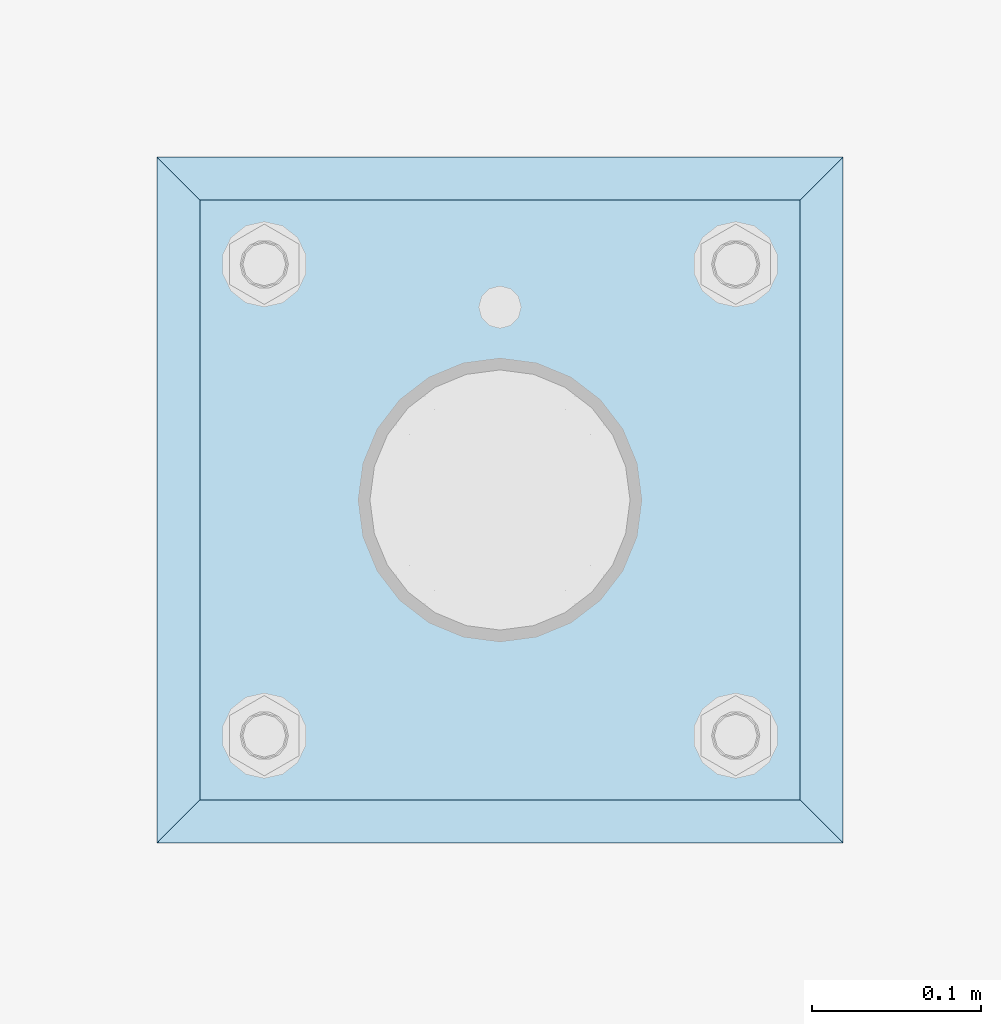
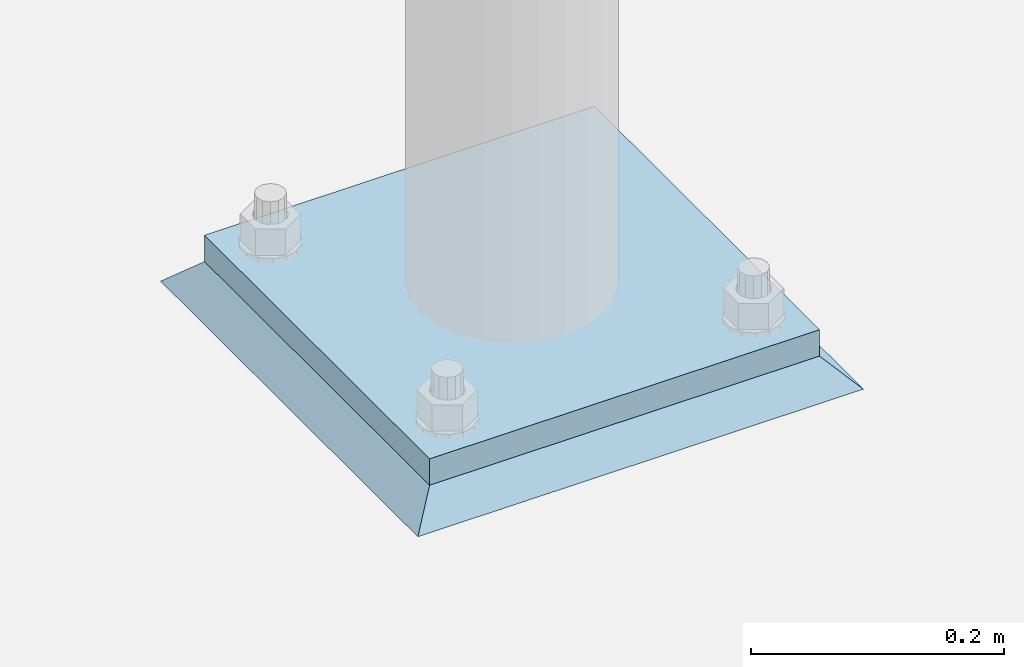
# One storey, part 3421 of 3843: 2 plates, 2 elements without a shape of their own.
"""IFC2X3 building model written with IfcOpenShell, lengths in millimetres."""

from ifc_helpers import new_model, si_unit, frame, origin_with_axes, place, context, subcontext, project, spatial, faceted_brep, material, type_object, element, aggregate, save


model = new_model("IFC2X3")

# Units and contexts
model_context = context("Model", 3, precision=1e-05, world=origin_with_axes())
body_context = subcontext(model_context, "Body", "Model", "MODEL_VIEW")
ifc_project = project(units=[si_unit("LENGTHUNIT", "METRE", prefix="MILLI"), si_unit("AREAUNIT", "SQUARE_METRE"), si_unit("VOLUMEUNIT", "CUBIC_METRE"), si_unit("MASSUNIT", "GRAM", prefix="KILO"), si_unit("TIMEUNIT", "SECOND"), si_unit("PLANEANGLEUNIT", "RADIAN"), si_unit("SOLIDANGLEUNIT", "STERADIAN"), si_unit("THERMODYNAMICTEMPERATUREUNIT", "DEGREE_CELSIUS"), si_unit("LUMINOUSINTENSITYUNIT", "LUMEN")], contexts=[model_context])

# Site, building, storey
site_placement = place(None, origin_with_axes())
site = spatial("IfcSite", under=ifc_project, at=site_placement, CompositionType="ELEMENT")
building_placement = place(site_placement, origin_with_axes())
building = spatial("IfcBuilding", under=site, at=building_placement, Name="Undefined", CompositionType="ELEMENT")
storey_placement = place(building_placement, origin_with_axes())
storey = spatial("IfcBuildingStorey", under=building, at=storey_placement, Name="Undefined", CompositionType="ELEMENT", Elevation=0.0)

# Assembly, plate
assembly_1_placement = place(storey_placement, origin_with_axes())
assembly_1 = element("IfcElementAssembly", 1, at=assembly_1_placement, inside=storey, Name="PIPE_BOLLARD", AssemblyPlace="NOTDEFINED", PredefinedType="RIGID_FRAME")
ifc_material_1 = material(Name="STEEL/A572-50")
plate_type_1 = type_object("IfcPlateType", PredefinedType="NOTDEFINED")
plate_1_placement = place(assembly_1_placement, frame((42672.0, 91427.3, 30518.1), z_axis=(0.0, 1.0, 0.0), x_axis=(1.0, 0.0, 0.0)))
plate_1 = element("IfcPlate", 2, at=plate_1_placement, type_object=plate_type_1, material=ifc_material_1, Name="PLATE", context=body_context, shape_type="Brep", body=[
    faceted_brep([(0.0, -12.6999999999971, 0.0), (0.0, -12.7000000000007, 355.600000000006), (0.0, 12.7000000000007, 355.600000000006), (0.0, 12.6999999999971, 0.0), (355.599999999999, -12.7000000000007, 355.600000000006), (355.599999999999, 12.7000000000007, 355.600000000006), (355.599999999999, -12.7000000000007, 0.0), (355.599999999999, 12.7000000000007, 0.0)], [[[0, 1, 2, 3]], [[1, 4, 5, 2]], [[4, 6, 7, 5]], [[6, 0, 3, 7]], [[5, 7, 3, 2]], [[6, 4, 1, 0]]]),
])
aggregate(assembly_1, [plate_1])

assembly_2_placement = place(storey_placement, origin_with_axes())
assembly_2 = element("IfcElementAssembly", 3, at=assembly_2_placement, inside=storey, Name="GROUT", AssemblyPlace="NOTDEFINED", PredefinedType="REINFORCEMENT_UNIT")
ifc_material_2 = material(Name="CONCRETE/Concrete_Undefined")
plate_type_2 = type_object("IfcPlateType", PredefinedType="NOTDEFINED")
plate_2_placement = place(assembly_2_placement, frame((42646.6, 91401.9, 30492.7), z_axis=(0.0, 1.0, 0.0), x_axis=(1.0, 0.0, 0.0)))
plate_2 = element("IfcPlate", 4, at=plate_2_placement, type_object=plate_type_2, material=ifc_material_2, Name="GROUT", context=body_context, shape_type="Brep", body=[
    faceted_brep([(25.4000000001906, -12.6999999998552, 380.999999999505), (0.0, 12.7000000000007, 406.399999999994), (0.0, 12.6999999999971, 0.0), (25.4000000001906, -12.6999999999898, 25.4000000004453), (380.999999999833, -12.6999999998588, 25.4000000004453), (406.400000000001, 12.7000000000007, 0.0), (406.400000000001, 12.7000000000007, 406.399999999994), (380.999999999833, -12.6999999999898, 380.999999999505)], [[[0, 1, 2, 3]], [[4, 5, 6, 7]], [[4, 7, 0, 3]], [[5, 4, 3, 2]], [[6, 5, 2, 1]], [[7, 6, 1, 0]]]),
])
aggregate(assembly_2, [plate_2])

save(model, "model.ifc")
